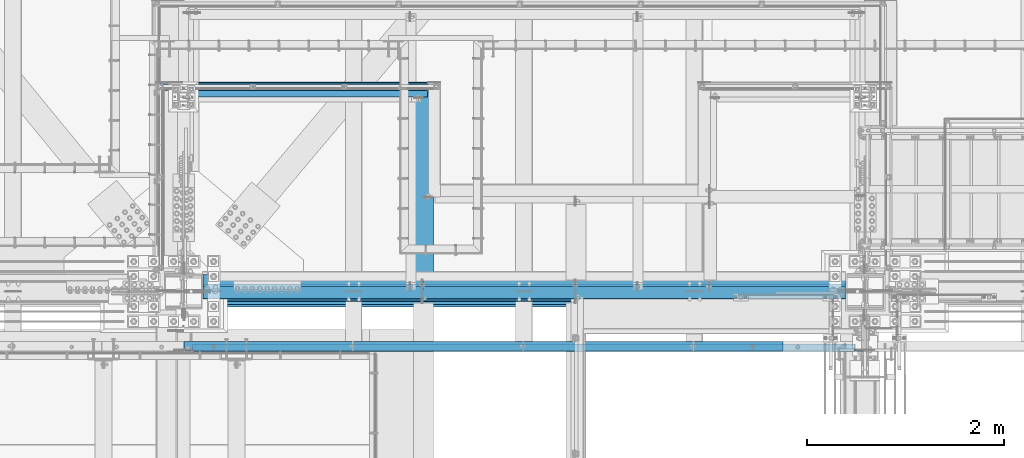
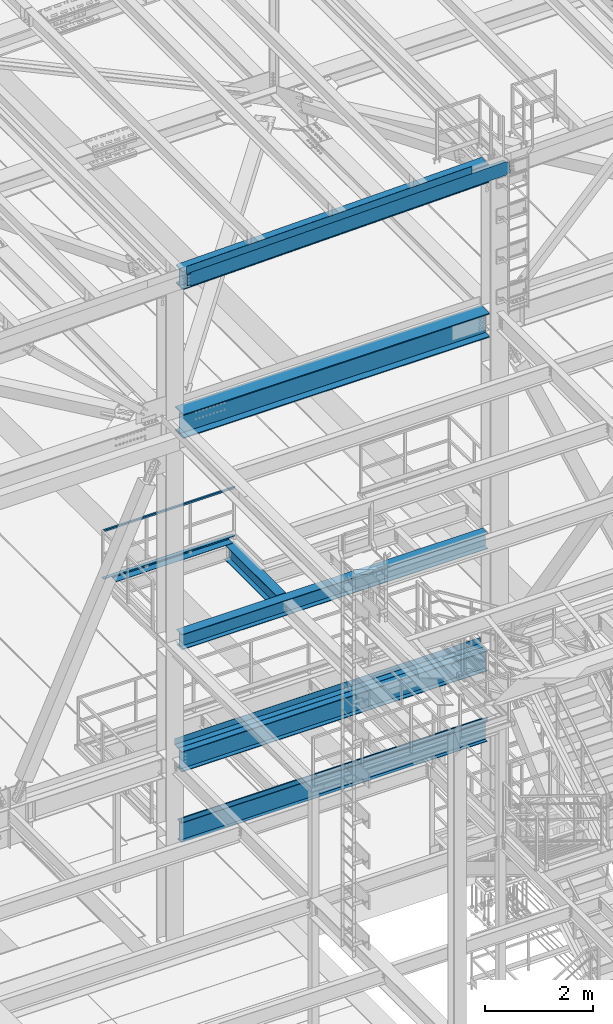
# One storey, part 1781 of 3843: 13 beams, 10 elements without a shape of their own.
"""IFC2X3 building model written with IfcOpenShell, lengths in millimetres."""

from ifc_helpers import new_model, si_unit, frame, origin_with_axes, place, context, subcontext, project, spatial, faceted_brep, material, type_object, element, aggregate, save


model = new_model("IFC2X3")

# Units and contexts
model_context = context("Model", 3, precision=1e-05, world=origin_with_axes())
body_context = subcontext(model_context, "Body", "Model", "MODEL_VIEW")
ifc_project = project(units=[si_unit("LENGTHUNIT", "METRE", prefix="MILLI"), si_unit("AREAUNIT", "SQUARE_METRE"), si_unit("VOLUMEUNIT", "CUBIC_METRE"), si_unit("MASSUNIT", "GRAM", prefix="KILO"), si_unit("TIMEUNIT", "SECOND"), si_unit("PLANEANGLEUNIT", "RADIAN"), si_unit("SOLIDANGLEUNIT", "STERADIAN"), si_unit("THERMODYNAMICTEMPERATUREUNIT", "DEGREE_CELSIUS"), si_unit("LUMINOUSINTENSITYUNIT", "LUMEN")], contexts=[model_context])

# Site, building, storey
site_placement = place(None, origin_with_axes())
site = spatial("IfcSite", under=ifc_project, at=site_placement, CompositionType="ELEMENT")
building_placement = place(site_placement, origin_with_axes())
building = spatial("IfcBuilding", under=site, at=building_placement, Name="Undefined", CompositionType="ELEMENT")
storey_placement = place(building_placement, origin_with_axes())
storey = spatial("IfcBuildingStorey", under=building, at=storey_placement, Name="Undefined", CompositionType="ELEMENT", Elevation=0.0)

# Assembly, beam
assembly_1_placement = place(storey_placement, origin_with_axes())
assembly_1 = element("IfcElementAssembly", 1, at=assembly_1_placement, inside=storey, Name="RAIL", AssemblyPlace="NOTDEFINED", PredefinedType="RIGID_FRAME")
ifc_material_1 = material()
beam_type_1 = type_object("IfcBeamType", Name="HSS1-1/2X1-1/2X1/4", PredefinedType="NOTDEFINED")
beam_1_placement = place(assembly_1_placement, frame((48761.649987793, 27701.8747862042, 38633.3999983618), z_axis=(0.0, 0.0, -1.0), x_axis=(1.0, 0.0, 0.0)))
beam_1 = element("IfcBeam", 2, at=beam_1_placement, type_object=beam_type_1, material=ifc_material_1, Name="RAIL", ObjectType="HSS1-1/2X1-1/2X1/4", context=body_context, shape_type="Brep", body=[
    faceted_brep([(19.0499992350015, 12.6999993299978, -12.6999993299978), (19.0499992350015, -12.6999993299978, -12.6999993299978), (2819.40001458878, -12.6999993300014, -12.6999993299978), (2819.40001458878, 12.6999993300014, -12.6999993299978), (19.0499992350015, -12.6999993299978, 12.6999993299978), (2794.00001592878, -12.6999993300014, 12.6999993299978), (19.0499992350015, 12.6999993299978, 12.6999993299978), (2794.00001592878, 12.6999993300014, 12.6999993299978), (19.0499992350015, 19.0499992350015, -19.0499992350015), (19.0499992350015, 19.0499992350015, 19.0499992350015), (2787.65001602378, 19.0499992350015, 19.0499992350015), (2825.75001449378, 19.0499992350015, -19.0499992350015), (19.0499992350015, -19.0499992350015, 19.0499992350015), (2787.65001602378, -19.0499992350015, 19.0499992350015), (19.0499992350015, -19.0499992350015, -19.0499992350015), (2825.75001449378, -19.0499992350015, -19.0499992350015)], [[[0, 1, 2, 3]], [[1, 4, 5, 2]], [[4, 6, 7, 5]], [[6, 0, 3, 7]], [[8, 9, 10, 11]], [[9, 12, 13, 10]], [[12, 14, 15, 13]], [[14, 8, 11, 15]], [[13, 15, 11, 10], [5, 7, 3, 2]], [[14, 12, 9, 8], [6, 4, 1, 0]]]),
])
aggregate(assembly_1, [beam_1])

assembly_2_placement = place(storey_placement, origin_with_axes())
assembly_2 = element("IfcElementAssembly", 3, at=assembly_2_placement, inside=storey, Name="ref.", AssemblyPlace="NOTDEFINED", PredefinedType="RIGID_FRAME")
ifc_material_2 = material(Name="STEEL/Steel_Undefined")
beam_type_2 = type_object("IfcBeamType", PredefinedType="NOTDEFINED")
beam_2_placement = place(assembly_2_placement, frame((51568.3500030517, 27701.8747862042, 37563.4249983618), z_axis=(0.0, -1.0, 0.0), x_axis=(-1.0, 0.0, 0.0)))
beam_2 = element("IfcBeam", 4, at=beam_2_placement, type_object=beam_type_2, material=ifc_material_2, Name="ref.", context=body_context, shape_type="Brep", body=[
    faceted_brep([(0.0, 3.17500000000291, -38.0999999999985), (0.0, 3.17500000000291, 38.0999999999985), (2806.70001525876, 3.17500000000291, 38.0999999999985), (2806.70001525876, 3.17500000000291, -38.0999999999985), (0.0, -3.17500000000291, 38.0999999999985), (2806.70001525876, -3.17500000000291, 38.0999999999985), (0.0, -3.17500000000291, -38.0999999999985), (2806.70001525876, -3.17500000000291, -38.0999999999985)], [[[0, 1, 2, 3]], [[1, 4, 5, 2]], [[4, 6, 7, 5]], [[6, 0, 3, 7]], [[5, 7, 3, 2]], [[6, 4, 1, 0]]]),
])
aggregate(assembly_2, [beam_2])

# Assembly, beams
assembly_3_placement = place(storey_placement, origin_with_axes())
assembly_3 = element("IfcElementAssembly", 5, at=assembly_3_placement, inside=storey, Name="BEAM", AssemblyPlace="NOTDEFINED", PredefinedType="RIGID_FRAME")
ifc_material_3 = material(Name="STEEL/A572-50")
beam_type_3 = type_object("IfcBeamType", Name="C12X20.7", PredefinedType="NOTDEFINED")
beam_3_placement = place(assembly_3_placement, frame((48993.2421028718, 25044.4000000754, 45839.8700236624), z_axis=(0.0211520550054438, 0.0, -0.999776270257025), x_axis=(0.999776270257024, 0.0, 0.0211520550054619)))
beam_3 = element("IfcBeam", 6, at=beam_3_placement, type_object=beam_type_3, material=ifc_material_3, Name="BEAM", ObjectType="C12X20.7", context=body_context, shape_type="Brep", body=[
    faceted_brep([(6837.32844832894, -38.1000000000058, -146.0474599929), (6837.32844832895, -38.1000000000058, -152.399999992893), (6837.32844832895, 38.1000000000058, -152.399999992893), (6837.32844832893, 38.1000000000058, -139.699999760349), (6837.32844832893, 1.395950675942e-06, -139.699999760349), (6838.29517825152, 38.1000000000058, -134.839920242324), (6838.29517825151, 30.1625000000058, -134.674927492917), (6841.04819215197, 38.1000000000058, -130.719743774185), (6841.04819215197, 30.1625000000058, -130.719743774185), (6845.1683686201, 38.1000000000058, -127.966729873719), (6845.1683686201, 30.1625000000058, -127.966729873719), (6850.02844813812, 38.1000000000058, -126.999999951135), (6850.02844813812, 30.1625000000058, -126.999999951135), (6919.87691954407, 30.1625000000058, -126.999999951055), (6919.87674076154, 38.1000000000058, -126.999999713284), (6837.32844832864, -38.1000000000058, 146.047460006623), (6837.32844832863, -38.1000000000058, 152.400000006615), (98.4250003414782, -38.1000000000058, 152.399999999863), (98.4250003414927, -38.1000000000058, 146.047459999871), (6837.32844832863, 38.1000000000058, 152.400000006615), (98.4250003414782, 38.1000000000058, 152.399999999863), (98.4250003414927, 38.1000000000058, 139.699999784301), (98.4250003414927, 1.29402906168252e-06, 139.699999784301), (98.4250003417692, 1.00112811196595e-06, -139.699999832876), (98.4250003417692, 38.1000000000058, -139.699999832876), (98.4250003417837, 38.1000000000058, -152.399999999638), (98.4250003417837, -38.1000000000058, -152.399999999638), (98.4250003417765, -38.1000000000058, -146.047459999652), (97.458270419178, 30.1625000000058, -134.674927499669), (97.4582704191853, 38.1000000000058, -134.839920314858), (94.7052565187187, 30.1625000000058, -130.719743846734), (94.7052565187187, 38.1000000000058, -130.719743846734), (90.5850800505723, 30.1625000000058, -127.966729946267), (90.5850800505723, 38.1000000000058, -127.966729946267), (85.725000532555, 30.1625000000058, -127.000000023691), (85.725000532555, 38.1000000000058, -127.000000023691), (15.8751155402206, 30.1625000000058, -126.999999954867), (15.8750003662499, 38.1000000000058, -127.000000023749), (15.8751166840084, 30.1624999999985, -114.300000158255), (15.8751155312566, 30.1624999999985, 116.299999836985), (15.8751168099407, 30.1625000000058, 127.00000004391), (15.8750006201954, 38.1000000000058, 126.999999975014), (85.7250005323076, 30.1625000000058, 126.99999997508), (85.7250005323076, 38.1000000000058, 126.99999997508), (90.5850800503176, 30.1625000000058, 127.966729897671), (90.5850800503176, 38.1000000000058, 127.966729897671), (94.7052565184495, 30.1625000000058, 130.719743798138), (94.7052565184495, 38.1000000000058, 130.719743798138), (97.4582704189161, 30.1625000000058, 134.674927499887), (97.4582704189233, 38.1000000000058, 134.839920266269), (6838.29517825124, 30.1625000000058, 134.674927506647), (6837.32844832865, 8.99206497706473e-07, 139.699999856828), (6837.32844832865, 38.1000000000058, 139.699999856828), (6838.29517825123, 38.1000000000058, 134.839920338811), (6841.04819215171, 30.1625000000058, 130.719743870679), (6841.04819215171, 38.1000000000058, 130.719743870679), (6845.16836861984, 30.1625000000058, 127.96672997022), (6845.16836861984, 38.1000000000058, 127.96672997022), (6850.02844813786, 30.1625000000058, 127.000000047636), (6850.02844813786, 38.1000000000058, 127.000000047636), (6919.87692259676, 30.1625000000058, 127.000000047708), (6919.87674203124, 38.1000000000058, 127.000000285479), (6919.87691955541, 30.1624999999985, 116.300000386036), (6919.87692232688, 30.1624999999985, -114.299999618583)], [[[0, 1, 2, 3, 4]], [[4, 3, 5, 6]], [[6, 5, 7, 8]], [[8, 7, 9, 10]], [[10, 9, 11, 12]], [[13, 12, 11, 14]], [[15, 16, 17, 18]], [[16, 19, 20, 17]], [[17, 20, 21, 22, 18]], [[23, 24, 25, 26, 27]], [[28, 29, 24, 23]], [[30, 31, 29, 28]], [[32, 33, 31, 30]], [[34, 35, 33, 32]], [[36, 37, 35, 34]], [[38, 39, 40, 41, 37, 36]], [[42, 43, 41, 40]], [[44, 45, 43, 42]], [[46, 47, 45, 44]], [[48, 49, 47, 46]], [[22, 21, 49, 48]], [[48, 50, 51, 15, 18, 22]], [[16, 15, 51, 52, 19]], [[50, 53, 52, 51]], [[54, 55, 53, 50]], [[56, 57, 55, 54]], [[58, 59, 57, 56]], [[60, 61, 59, 58]], [[61, 60, 62, 63, 13, 14]], [[31, 33, 35, 37, 41, 43, 45, 47, 49, 21, 20, 19, 52, 53, 55, 57, 59, 61, 14, 11, 9, 7, 5, 3, 2, 25, 24, 29]], [[2, 1, 26, 25]], [[1, 0, 27, 26]], [[0, 4, 6, 28, 23, 27]], [[63, 62, 60, 58, 56, 54, 50, 48, 46, 44, 42, 40, 39, 38, 36, 34, 32, 30, 28, 6, 8, 10, 12, 13]]]),
])
ifc_material_4 = material(Name="STEEL/A36")
beam_type_4 = type_object("IfcBeamType", PredefinedType="NOTDEFINED")
beam_4_placement = place(assembly_3_placement, frame((52047.2330885058, 25107.8999997352, 46060.0926064624), z_axis=(0.999776270257024, 0.0, 0.0211520550054619), x_axis=(0.0, -1.0, 0.0)))
beam_4 = element("IfcBeam", 7, at=beam_4_placement, type_object=beam_type_4, material=ifc_material_4, Name="BENT_PLATE", context=body_context, shape_type="Brep", body=[
    faceted_brep([(-3.50355549016967e-07, -3.17499999742722, -3048.00000001723), (3.50421032635495e-07, -3.17500000260043, 3048.00000001724), (3.5035191103816e-07, 3.17499999739084, 3048.00000001724), (-3.50424670614302e-07, 3.17500000256405, -3048.00000001723), (101.599999864371, 3.17499999856227, 3048.00000000522), (101.599998739839, 3.17500000373548, -3048.00000002925), (95.249998765099, -3.17499999632128, -3048.00000002851), (95.2499998896274, -3.17500000149448, 3048.00000000597), (101.600000309205, -161.925000875126, 3047.9999999938), (101.599999608374, -161.925000446165, -3048.00000004067), (95.2500003092064, -161.925000900388, 3047.99999999456), (95.2499996083752, -161.925000471427, -3048.00000003992)], [[[0, 1, 2, 3]], [[3, 2, 4, 5]], [[1, 0, 6, 7]], [[5, 4, 8, 9]], [[4, 2, 1, 7, 10, 8]], [[7, 6, 11, 10]], [[6, 0, 3, 5, 9, 11]], [[10, 11, 9, 8]]]),
])
aggregate(assembly_3, [beam_4, beam_3])

# Assembly, beam
assembly_4_placement = place(storey_placement, origin_with_axes())
assembly_4 = element("IfcElementAssembly", 8, at=assembly_4_placement, inside=storey, Name="BEAM", AssemblyPlace="NOTDEFINED", PredefinedType="RIGID_FRAME")
ifc_material_5 = material(Name="STEEL/A992")
beam_type_5 = type_object("IfcBeamType", Name="W21X101", PredefinedType="NOTDEFINED")
beam_5_placement = place(assembly_4_placement, frame((48996.6, 25615.9, 42197.3375), z_axis=(0.0, 0.0, 1.0), x_axis=(1.0, 0.0, 0.0)))
beam_5 = element("IfcBeam", 9, at=beam_5_placement, type_object=beam_type_5, material=ifc_material_5, Name="BEAM", ObjectType="W21X101", context=body_context, shape_type="Brep", body=[
    faceted_brep([(6735.76249999998, 6.34999999999854, -250.824999999997), (6735.76249999998, 155.575000000001, -250.824999999997), (196.850000000006, 155.575000000001, -250.824999999997), (196.850000000006, 6.34999999999854, -250.824999999997), (6735.76249999998, -155.575000000001, -271.462500000001), (6735.76249999998, -155.575000000001, -250.824999999997), (196.850000000006, -155.575000000001, -250.824999999997), (196.850000000006, -155.575000000001, -271.462500000001), (6735.76249999998, 155.575000000001, -271.462500000001), (196.850000000006, 155.575000000001, -271.462500000001), (6735.76249999998, 6.34999999999854, -180.127500000199), (6735.76249999998, 6.34999999999854, 215.052499997902), (6735.76249999998, 6.34999999999854, 250.824999999997), (6735.76249999998, 155.575000000001, 250.824999999997), (6735.76249999998, 155.575000000001, 271.462500000001), (6735.76249999998, -155.575000000001, 271.462500000001), (6735.76249999998, -155.575000000001, 250.824999999997), (6735.76249999998, -6.34999999999854, 250.824999999997), (6735.76249999998, -6.34999999999854, -250.824999999997), (193.675000000003, 6.35000000000036, 250.428), (193.675000000003, -6.35000000000036, 250.428), (193.675000000003, -6.35000000000036, 250.824999999997), (193.675000000003, 6.35000000000036, 250.824999999997), (228.60000000002, 6.35000000000036, 250.428), (228.60000000002, -6.35000000000036, 250.428), (273.984905435093, 6.35000000000036, 234.406795689014), (273.984905435093, -6.35000000000036, 234.406795689014), (278.274267898814, 6.35000000000036, 231.347328818971), (278.274267898814, -6.35000000000036, 231.347328818971), (280.281122181914, 6.35000000000036, 226.475829690324), (280.281122181914, -6.35000000000036, 226.475829690324), (279.391438807783, 6.35000000000036, 221.282812131351), (279.391438807783, -6.35000000000036, 221.282812131351), (275.877430772234, 6.35000000000036, 217.357163726287), (275.877430772234, -6.35000000000036, 217.357163726287), (270.814265581474, 6.35000000000036, 215.900000000001), (270.814265581474, -6.35000000000036, 215.900000000001), (196.85001722983, 6.34999999999854, 215.900000000001), (196.85001722983, -6.34999999999854, 215.900000000001), (196.850000000006, -6.34999999999854, -250.824999999997), (193.675000000003, 155.575000000001, 250.824999999997), (205.589601116109, 155.575000000001, 271.462500000001), (205.589601116109, -155.575000000001, 271.462500000001), (193.675000000003, -155.575000000001, 250.824999999997)], [[[0, 1, 2, 3]], [[4, 5, 6, 7]], [[8, 4, 7, 9]], [[1, 8, 9, 2]], [[0, 10, 11, 12, 13, 14, 15, 16, 17, 18, 5, 4, 8, 1]], [[19, 20, 21, 22]], [[23, 24, 20, 19]], [[24, 23, 25, 26]], [[26, 25, 27, 28]], [[28, 27, 29, 30]], [[30, 29, 31, 32]], [[32, 31, 33, 34]], [[34, 33, 35, 36]], [[36, 35, 37, 38]], [[18, 17, 21, 20, 24, 26, 28, 30, 32, 34, 36, 38, 39]], [[5, 18, 39, 6]], [[38, 37, 3, 2, 9, 7, 6, 39]], [[35, 33, 31, 29, 27, 25, 23, 19, 22, 12, 11, 10, 0, 3, 37]], [[13, 12, 22, 40]], [[14, 13, 40, 41]], [[15, 14, 41, 42]], [[16, 15, 42, 43]], [[17, 16, 43, 21]], [[42, 41, 40, 22, 21, 43]]]),
])
aggregate(assembly_4, [beam_5])

assembly_5_placement = place(storey_placement, origin_with_axes())
assembly_5 = element("IfcElementAssembly", 10, at=assembly_5_placement, inside=storey, Name="BEAM", AssemblyPlace="NOTDEFINED", PredefinedType="RIGID_FRAME")
beam_type_6 = type_object("IfcBeamType", PredefinedType="NOTDEFINED")
beam_6_placement = place(assembly_5_placement, frame((52462.906, 25666.7, 33200.975), z_axis=(-1.0, 0.0, 0.0), x_axis=(0.0, -1.0, 0.0)))
beam_6 = element("IfcBeam", 11, at=beam_6_placement, type_object=beam_type_6, material=ifc_material_4, Name="BENT_PLATE", context=body_context, shape_type="Brep", body=[
    faceted_brep([(0.0, -3.17500000000291, -3269.456), (0.0, -3.17500000000291, 3269.456), (0.0, 3.17500000000291, 3269.456), (0.0, 3.17500000000291, -3269.456), (120.649999999998, 3.17500000000291, 3269.456), (120.649999999998, 3.17500000000291, -3269.456), (126.999999999996, -3.17500000000291, -3269.456), (126.999999999996, -3.17500000000291, 3269.456), (120.649999999998, 98.4249984741182, 3269.456), (120.649999999998, 98.4249984741182, -3269.456), (126.999999999996, 98.4249984741182, 3269.456), (126.999999999996, 98.4249984741182, -3269.456)], [[[0, 1, 2, 3]], [[3, 2, 4, 5]], [[1, 0, 6, 7]], [[5, 4, 8, 9]], [[4, 2, 1, 7, 10, 8]], [[7, 6, 11, 10]], [[6, 0, 3, 5, 9, 11]], [[10, 11, 9, 8]]]),
])

assembly_6_placement = place(storey_placement, origin_with_axes())
assembly_6 = element("IfcElementAssembly", 12, at=assembly_6_placement, inside=storey, Name="BEAM", AssemblyPlace="NOTDEFINED", PredefinedType="RIGID_FRAME")
beam_type_7 = type_object("IfcBeamType", PredefinedType="NOTDEFINED")
beam_7_placement = place(assembly_6_placement, frame((52462.906, 25660.35, 34813.875), z_axis=(-1.0, 0.0, 0.0), x_axis=(0.0, 1.0, 0.0)))
beam_7 = element("IfcBeam", 13, at=beam_7_placement, type_object=beam_type_7, material=ifc_material_4, Name="BENT_PLATE", context=body_context, shape_type="Brep", body=[
    faceted_brep([(0.0, -3.17500000000291, -3269.456), (0.0, -3.17500000000291, 3269.456), (0.0, 3.17500000000291, 3269.456), (0.0, 3.17500000000291, -3269.456), (133.349999999995, 3.17500000000291, 3269.456), (133.349999999995, 3.17500000000291, -3269.456), (126.999999999996, -3.17500000000291, -3269.456), (126.999999999996, -3.17500000000291, 3269.456), (133.349999999995, -136.524999999994, 3269.456), (133.349999999995, -136.524999999994, -3269.456), (126.999999999996, -136.524999999994, 3269.456), (126.999999999996, -136.524999999994, -3269.456)], [[[0, 1, 2, 3]], [[3, 2, 4, 5]], [[1, 0, 6, 7]], [[5, 4, 8, 9]], [[4, 2, 1, 7, 10, 8]], [[7, 6, 11, 10]], [[6, 0, 3, 5, 9, 11]], [[10, 11, 9, 8]]]),
])

assembly_7_placement = place(storey_placement, origin_with_axes())
assembly_7 = element("IfcElementAssembly", 14, at=assembly_7_placement, inside=storey, Name="BEAM", AssemblyPlace="NOTDEFINED", PredefinedType="RIGID_FRAME")
beam_type_8 = type_object("IfcBeamType", PredefinedType="NOTDEFINED")
beam_8_placement = place(assembly_7_placement, frame((50234.453, 27597.1, 37468.175), z_axis=(-1.0, 0.0, 0.0), x_axis=(0.0, 1.0, 0.0)))
beam_8 = element("IfcBeam", 15, at=beam_8_placement, type_object=beam_type_8, material=ifc_material_4, Name="BENT_PLATE", context=body_context, shape_type="Brep", body=[
    faceted_brep([(0.0, -3.17500000000291, -1244.203), (0.0, -3.17500000000291, 1244.203), (0.0, 3.17500000000291, 1244.203), (0.0, 3.17500000000291, -1244.203), (149.224999999995, 3.17500000000291, 1244.203), (149.224999999995, 3.17500000000291, -1244.203), (142.874999999996, -3.17500000000291, -1244.203), (142.874999999996, -3.17500000000291, 1244.203), (149.224999999995, -98.4249999999956, 1244.203), (149.224999999995, -98.4249999999956, -1244.203), (142.874999999996, -98.4249999999956, 1244.203), (142.874999999996, -98.4249999999956, -1244.203)], [[[0, 1, 2, 3]], [[3, 2, 4, 5]], [[1, 0, 6, 7]], [[5, 4, 8, 9]], [[4, 2, 1, 7, 10, 8]], [[7, 6, 11, 10]], [[6, 0, 3, 5, 9, 11]], [[10, 11, 9, 8]]]),
])
aggregate(assembly_7, [beam_8])

# Beam
beam_type_9 = type_object("IfcBeamType", Name="W18X35", PredefinedType="NOTDEFINED")
beam_9_placement = place(assembly_5_placement, frame((48996.6, 25615.9, 32972.375), z_axis=(0.0, 0.0, 1.0), x_axis=(1.0, 0.0, 0.0)))
beam_9 = element("IfcBeam", 16, at=beam_9_placement, type_object=beam_type_9, material=ifc_material_5, Name="BEAM", ObjectType="W18X35", context=body_context, shape_type="Brep", body=[
    faceted_brep([(196.849999999999, -76.2000000000007, -225.424999999999), (196.849999999999, 76.2000000000007, -225.424999999999), (6735.76249999999, 76.2000000000007, -225.424999999999), (6735.76249999999, -76.2000000000007, -225.424999999999), (196.849999999999, -76.2000000000007, -214.3125), (196.849999999999, -3.96875, -214.3125), (196.849999999999, -3.96875, -118.214985131715), (196.849999999999, -3.96875, 188.064999999995), (196.849999999999, -3.96875, 214.3125), (196.849999999999, -76.2000000000007, 214.3125), (196.849999999999, -76.2000000000007, 225.425000000003), (196.849999999999, 76.2000000000007, 225.425000000003), (196.849999999999, 76.2000000000007, 214.3125), (196.849999999999, 3.96875, 214.3125), (196.849999999999, 3.96875, -214.3125), (196.849999999999, 76.2000000000007, -214.3125), (6735.76249999999, -76.2000000000007, -214.3125), (6735.76249999999, -3.96875, -214.3125), (6735.76249999999, -3.96875, -118.214985131715), (6735.76249999999, -3.96875, 188.064999999995), (6735.76249999999, -3.96875, 214.3125), (6735.76249999999, -76.2000000000007, 214.3125), (6735.76249999999, -76.2000000000007, 225.425000000003), (6735.76249999999, 76.2000000000007, 225.425000000003), (6735.76249999999, 76.2000000000007, 214.3125), (6735.76249999999, 3.96875, 214.3125), (6735.76249999999, 3.96875, -214.3125), (6735.76249999999, 76.2000000000007, -214.3125)], [[[0, 1, 2, 3]], [[0, 4, 5, 6, 7, 8, 9, 10, 11, 12, 13, 14, 15, 1]], [[5, 4, 16, 17]], [[8, 7, 6, 5, 17, 18, 19, 20]], [[9, 8, 20, 21]], [[10, 9, 21, 22]], [[11, 10, 22, 23]], [[12, 11, 23, 24]], [[13, 12, 24, 25]], [[14, 13, 25, 26]], [[15, 14, 26, 27]], [[1, 15, 27, 2]], [[26, 25, 24, 23, 22, 21, 20, 19, 18, 17, 16, 3, 2, 27]], [[4, 0, 3, 16]]]),
])

aggregate(assembly_5, [beam_6, beam_9])

# Assembly, beam
assembly_8_placement = place(storey_placement, origin_with_axes())
assembly_8 = element("IfcElementAssembly", 17, at=assembly_8_placement, inside=storey, Name="BEAM", AssemblyPlace="NOTDEFINED", PredefinedType="RIGID_FRAME")
beam_type_10 = type_object("IfcBeamType", Name="W16X67", PredefinedType="NOTDEFINED")
beam_10_placement = place(assembly_8_placement, frame((49000.998843013, 25615.9, 45473.239573685), z_axis=(-0.0211520980073474, 0.0, 0.999776269347241), x_axis=(0.999776270257024, 0.0, 0.0211520550054619)))
beam_10 = element("IfcBeam", 18, at=beam_10_placement, type_object=beam_type_10, material=ifc_material_5, Name="BEAM", ObjectType="W16X67", context=body_context, shape_type="Brep", body=[
    faceted_brep([(188.094396478875, -130.174999999999, -207.962499999492), (188.094396478875, 130.174999999999, -207.962499999492), (6728.47017867771, 130.174999999999, -207.9624999929), (6728.47017867771, -130.174999999999, -207.9624999929), (188.463847647872, -130.174999999999, -190.49999999952), (188.463847647872, -4.76250000000073, -190.49999999952), (196.524600426201, -4.76250000000073, 190.499999999869), (196.524600426201, -130.174999999999, 190.499999999869), (196.894051595213, -130.174999999999, 207.962499999841), (196.894051595213, 130.174999999999, 207.962499999841), (196.524600426201, 130.174999999999, 190.499999999869), (196.524600426201, 4.76250000000073, 190.499999999869), (195.989385299312, 4.76250000000073, 165.202490022384), (189.242289076908, 4.76250000000073, -153.706144372954), (188.463847647872, 4.76250000000073, -190.49999999952), (188.463847647872, 130.174999999999, -190.49999999952), (6728.83962984671, -130.174999999999, -190.499999992928), (6728.83962984671, -4.76250000000073, -190.499999992928), (6736.90038262498, -4.76250000000073, 190.500000006468), (6736.90038262498, -130.174999999999, 190.500000006468), (6737.26983379398, -130.174999999999, 207.962500006441), (6737.26983379398, 130.174999999999, 207.962500006441), (6736.90038262498, 130.174999999999, 190.500000006468), (6736.90038262498, 4.76250000000073, 190.500000006468), (6736.3253837095, 4.76250000000073, 163.322068512665), (6729.57828748714, 4.76250000000073, -155.586565882681), (6728.83962984671, 4.76250000000073, -190.499999992928), (6728.83962984671, 130.174999999999, -190.499999992928)], [[[0, 1, 2, 3]], [[0, 4, 5, 6, 7, 8, 9, 10, 11, 12, 13, 14, 15, 1]], [[5, 4, 16, 17]], [[6, 5, 17, 18]], [[7, 6, 18, 19]], [[8, 7, 19, 20]], [[9, 8, 20, 21]], [[10, 9, 21, 22]], [[11, 10, 22, 23]], [[14, 13, 12, 11, 23, 24, 25, 26]], [[15, 14, 26, 27]], [[1, 15, 27, 2]], [[26, 25, 24, 23, 22, 21, 20, 19, 18, 17, 16, 3, 2, 27]], [[4, 0, 3, 16]]]),
])
aggregate(assembly_8, [beam_10])

# Beam
beam_type_11 = type_object("IfcBeamType", Name="W18X50", PredefinedType="NOTDEFINED")
beam_11_placement = place(assembly_6_placement, frame((48996.6, 25615.9, 34582.1), z_axis=(0.0, 0.0, 1.0), x_axis=(1.0, 0.0, 0.0)))
beam_11 = element("IfcBeam", 19, at=beam_11_placement, type_object=beam_type_11, material=ifc_material_5, Name="BEAM", ObjectType="W18X50", context=body_context, shape_type="Brep", body=[
    faceted_brep([(196.849999999999, 95.25, -228.599999999999), (196.849999999999, 95.25, -214.3125), (6735.7625, 95.25, -214.3125), (6735.7625, 95.25, -228.599999999999), (196.849999999999, 4.76250000000073, -214.3125), (6735.7625, 4.76250000000073, -214.3125), (196.849999999999, 4.76250000000073, 214.3125), (6735.7625, 4.76250000000073, 214.3125), (196.849999999999, 95.25, 214.3125), (6735.7625, 95.25, 214.3125), (196.849999999999, 95.25, 228.599999999999), (6735.7625, 95.25, 228.599999999999), (196.849999999999, -95.25, 228.599999999999), (6735.7625, -95.25, 228.599999999999), (196.849999999999, -95.25, 214.3125), (6735.7625, -95.25, 214.3125), (196.849999999999, -4.76250000000073, 214.3125), (6735.7625, -4.76250000000073, 214.3125), (196.849999999999, -4.76250000000073, -214.3125), (6735.7625, -4.76250000000073, -214.3125), (196.849999999999, -95.25, -214.3125), (6735.7625, -95.25, -214.3125), (196.849999999999, -95.25, -228.599999999999), (6735.7625, -95.25, -228.599999999999)], [[[0, 1, 2, 3]], [[1, 4, 5, 2]], [[4, 6, 7, 5]], [[6, 8, 9, 7]], [[8, 10, 11, 9]], [[10, 12, 13, 11]], [[12, 14, 15, 13]], [[14, 16, 17, 15]], [[16, 18, 19, 17]], [[18, 20, 21, 19]], [[20, 22, 23, 21]], [[22, 0, 3, 23]], [[5, 7, 9, 11, 13, 15, 17, 19, 21, 23, 3, 2]], [[22, 20, 18, 16, 14, 12, 10, 8, 6, 4, 1, 0]]]),
])

aggregate(assembly_6, [beam_7, beam_11])

# Assembly, beam
assembly_9_placement = place(storey_placement, origin_with_axes())
assembly_9 = element("IfcElementAssembly", 20, at=assembly_9_placement, inside=storey, Name="BEAM", AssemblyPlace="NOTDEFINED", PredefinedType="RIGID_FRAME")
beam_type_12 = type_object("IfcBeamType", Name="W14X43", PredefinedType="NOTDEFINED")
beam_12_placement = place(assembly_9_placement, frame((51435.0, 25615.9, 37291.9625), z_axis=(0.0, 0.0, 1.0), x_axis=(0.0, 1.0, 0.0)))
beam_12 = element("IfcBeam", 21, at=beam_12_placement, type_object=beam_type_12, material=ifc_material_5, Name="BEAM", ObjectType="W14X43", context=body_context, shape_type="Brep", body=[
    faceted_brep([(117.664320801076, -101.599999999999, 173.037499999999), (117.664320801076, 101.599999999999, 173.037499999999), (110.3317630852, 101.599999999999, 160.337500000001), (110.3317630852, 3.96875, 160.337500000001), (110.102548455761, 3.96875, 159.940499948083), (110.102548455761, -3.96875, 159.940499948083), (110.3317630852, -3.96875, 160.337500000001), (110.3317630852, -101.599999999999, 160.337500000001), (123.031750000006, -3.96875, 159.940499999997), (123.031750000006, 3.96875, 159.940499999997), (150.805846741696, 3.96875, 150.284265447786), (150.805846741696, -3.96875, 150.284265447786), (155.115364045432, 3.96875, 147.238154167171), (155.115364045432, -3.96875, 147.238154167171), (157.141757621015, 3.96875, 142.365325173465), (157.141757621015, -3.96875, 142.365325173465), (156.262970011077, 3.96875, 137.161627866575), (156.262970011077, -3.96875, 137.161627866575), (152.748769336082, 3.96875, 133.224480810524), (152.748769336082, -3.96875, 133.224480810524), (147.67793652137, 3.96875, 131.762499999997), (147.67793652137, -3.96875, 131.762499999997), (16.668750000008, 3.96875, 131.762499999997), (16.668750000008, -3.96875, 131.762499999997), (16.668750000008, 3.96875, -131.762499999997), (16.668750000008, -3.96875, -131.762499999997), (149.118936521369, 3.96875, -131.762499999997), (149.118936521369, -3.96875, -131.762499999997), (154.189769336084, 3.96875, -133.224480810524), (154.189769336084, -3.96875, -133.224480810524), (157.70397001108, 3.96875, -137.161627866575), (157.70397001108, -3.96875, -137.161627866575), (158.582757621018, 3.96875, -142.365325173465), (158.582757621018, -3.96875, -142.365325173465), (156.556364045435, 3.96875, -147.238154167171), (156.556364045435, -3.96875, -147.238154167171), (152.246846741695, 3.96875, -150.284265447786), (152.246846741695, -3.96875, -150.284265447786), (124.472750000008, 3.96875, -159.940499999997), (124.472750000008, -3.96875, -159.940499999997), (117.893546962492, 3.96875, -159.940499999997), (117.893546962492, -3.96875, -159.940499999997), (2032.0, 3.96875, -160.337500000001), (2032.0, 101.599999999999, -160.337500000001), (117.664343924978, 101.599999999999, -160.337500000001), (117.664343924978, 3.96875, -160.337500000001), (2032.0, 101.599999999999, -173.037499999999), (2032.0, -101.599999999999, -173.037499999999), (110.332156075034, -101.599999999999, -173.037499999999), (110.332156075034, 101.599999999999, -173.037499999999), (2032.0, -101.599999999999, -160.337500000001), (117.664343924978, -101.599999999999, -160.337500000001), (2032.0, -3.96875, -160.337500000001), (117.664343924978, -3.96875, -160.337500000001), (2032.0, 3.96875, 160.337500000001), (2032.0, 101.599999999999, 160.337500000001), (2032.0, 101.599999999999, 173.037499999999), (2032.0, -101.599999999999, 173.037499999999), (2032.0, -101.599999999999, 160.337500000001), (2032.0, -3.96875, 160.337500000001)], [[[0, 1, 2, 3, 4, 5, 6, 7]], [[8, 9, 10, 11]], [[11, 10, 12, 13]], [[13, 12, 14, 15]], [[15, 14, 16, 17]], [[17, 16, 18, 19]], [[19, 18, 20, 21]], [[21, 20, 22, 23]], [[23, 22, 24, 25]], [[26, 27, 25, 24]], [[27, 26, 28, 29]], [[29, 28, 30, 31]], [[31, 30, 32, 33]], [[33, 32, 34, 35]], [[35, 34, 36, 37]], [[37, 36, 38, 39]], [[39, 38, 40, 41]], [[42, 43, 44, 45]], [[46, 47, 48, 49]], [[47, 50, 51, 48]], [[50, 52, 53, 51]], [[41, 40, 45, 44, 49, 48, 51, 53]], [[43, 46, 49, 44]], [[42, 54, 55, 56, 57, 58, 59, 52, 50, 47, 46, 43]], [[58, 57, 0, 7]], [[59, 58, 7, 6]], [[8, 11, 13, 15, 17, 19, 21, 23, 25, 27, 29, 31, 33, 35, 37, 39, 41, 53, 52, 59, 6, 5]], [[9, 8, 5, 4]], [[54, 42, 45, 40, 38, 36, 34, 32, 30, 28, 26, 24, 22, 20, 18, 16, 14, 12, 10, 9, 4, 3]], [[55, 54, 3, 2]], [[56, 55, 2, 1]], [[57, 56, 1, 0]]]),
])
aggregate(assembly_9, [beam_12])

assembly_10_placement = place(storey_placement, origin_with_axes())
assembly_10 = element("IfcElementAssembly", 22, at=assembly_10_placement, inside=storey, Name="BEAM", AssemblyPlace="NOTDEFINED", PredefinedType="RIGID_FRAME")
beam_13_placement = place(assembly_10_placement, frame((48996.6, 25615.9, 37291.9625), z_axis=(0.0, 0.0, 1.0), x_axis=(1.0, 0.0, 0.0)))
beam_13 = element("IfcBeam", 23, at=beam_13_placement, type_object=beam_type_12, material=ifc_material_5, Name="BEAM", ObjectType="W14X43", context=body_context, shape_type="Brep", body=[
    faceted_brep([(196.849999999999, -101.599999999999, -173.037499999999), (196.849999999999, 101.599999999999, -173.037499999999), (6735.7625, 101.599999999999, -173.037499999999), (6735.7625, -101.599999999999, -173.037499999999), (196.849999999999, -101.599999999999, -160.337500000001), (196.849999999999, -3.96875, -160.337500000001), (196.849999999999, -3.96875, 160.337500000001), (196.849999999999, -101.599999999999, 160.337500000001), (196.849999999999, -101.599999999999, 173.037499999999), (196.849999999999, 101.599999999999, 173.037499999999), (196.849999999999, 101.599999999999, 160.337500000001), (196.849999999999, 3.96875, 160.337500000001), (196.849999999999, 3.96875, 135.677499999998), (196.849999999999, 3.96875, -94.4025034422593), (196.849999999999, 3.96875, -160.337500000001), (196.849999999999, 101.599999999999, -160.337500000001), (6735.7625, -101.599999999999, -160.337500000001), (6735.7625, -3.96875, -160.337500000001), (6735.7625, -3.96875, 160.337500000001), (6735.7625, -101.599999999999, 160.337500000001), (6735.7625, -101.599999999999, 173.037499999999), (6735.7625, 101.599999999999, 173.037499999999), (6735.7625, 101.599999999999, 160.337500000001), (6735.7625, 3.96875, 160.337500000001), (6735.7625, 3.96875, 135.677499999998), (6735.7625, 3.96875, -94.4025034422593), (6735.7625, 3.96875, -160.337500000001), (6735.7625, 101.599999999999, -160.337500000001)], [[[0, 1, 2, 3]], [[0, 4, 5, 6, 7, 8, 9, 10, 11, 12, 13, 14, 15, 1]], [[5, 4, 16, 17]], [[6, 5, 17, 18]], [[7, 6, 18, 19]], [[8, 7, 19, 20]], [[9, 8, 20, 21]], [[10, 9, 21, 22]], [[11, 10, 22, 23]], [[14, 13, 12, 11, 23, 24, 25, 26]], [[15, 14, 26, 27]], [[1, 15, 27, 2]], [[26, 25, 24, 23, 22, 21, 20, 19, 18, 17, 16, 3, 2, 27]], [[4, 0, 3, 16]]]),
])
aggregate(assembly_10, [beam_13])

save(model, "model.ifc")
